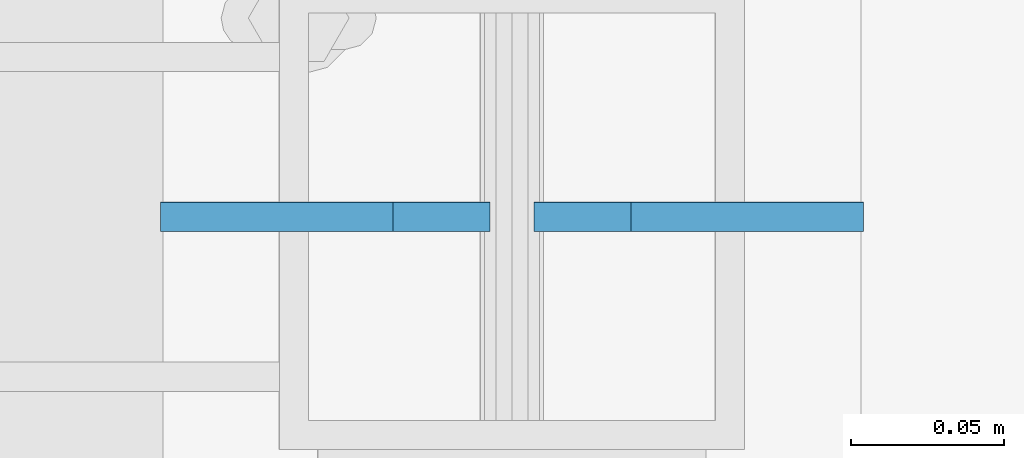
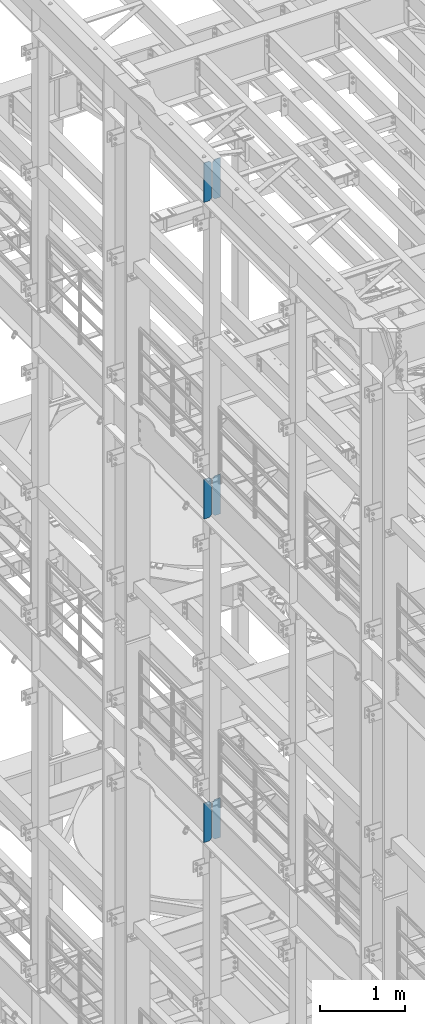
# One storey, part 1623 of 1876: 6 plates, 3 elements without a shape of their own.
"""IFC2X3 building model written with IfcOpenShell, lengths in millimetres."""

from ifc_helpers import new_model, si_unit, frame, origin_with_axes, place, context, subcontext, project, spatial, faceted_brep, material, type_object, element, aggregate, save


model = new_model("IFC2X3")

# Units and contexts
model_context = context("Model", 3, precision=1e-05, world=origin_with_axes())
body_context = subcontext(model_context, "Body", "Model", "MODEL_VIEW")
ifc_project = project(units=[si_unit("LENGTHUNIT", "METRE", prefix="MILLI"), si_unit("AREAUNIT", "SQUARE_METRE"), si_unit("VOLUMEUNIT", "CUBIC_METRE"), si_unit("MASSUNIT", "GRAM", prefix="KILO"), si_unit("TIMEUNIT", "SECOND"), si_unit("PLANEANGLEUNIT", "RADIAN"), si_unit("SOLIDANGLEUNIT", "STERADIAN"), si_unit("THERMODYNAMICTEMPERATUREUNIT", "DEGREE_CELSIUS"), si_unit("LUMINOUSINTENSITYUNIT", "LUMEN")], contexts=[model_context])

# Site, building, storey
site_placement = place(None, origin_with_axes())
site = spatial("IfcSite", under=ifc_project, at=site_placement, CompositionType="ELEMENT")
building_placement = place(site_placement, origin_with_axes())
building = spatial("IfcBuilding", under=site, at=building_placement, Name="Undefined", CompositionType="ELEMENT")
storey_placement = place(building_placement, origin_with_axes())
storey = spatial("IfcBuildingStorey", under=building, at=storey_placement, Name="Undefined", CompositionType="ELEMENT", Elevation=0.0)

# Assembly, plates
assembly_1_placement = place(storey_placement, origin_with_axes())
assembly_1 = element("IfcElementAssembly", 1, at=assembly_1_placement, inside=storey, Name="BEAM", AssemblyPlace="NOTDEFINED", PredefinedType="RIGID_FRAME")
ifc_material = material(Name="STEEL/A36")
plate_type = type_object("IfcPlateType", PredefinedType="NOTDEFINED")
plate_1_placement = place(assembly_1_placement, frame((115.093750392656, 5588.00666373244, 21958.3), z_axis=(0.0, 0.0, 1.0), x_axis=(-1.0, 0.0, 0.0)))
plate_1 = element("IfcPlate", 2, at=plate_1_placement, type_object=plate_type, material=ifc_material, Name="PLATE", context=body_context, shape_type="Brep", body=[
    faceted_brep([(0.0, -4.76249999999982, 0.0), (0.0, -4.76249999999982, 571.5), (0.0, 4.76249999999982, 571.5), (0.0, 4.76249999999982, 0.0), (76.1999969482422, -4.76249999999982, 571.5), (76.1999969482422, 4.76249999999982, 571.5), (107.949996948242, -4.76249999999982, 539.75), (107.949996948242, 4.76249999999982, 539.75), (107.949996948242, -4.76249999999982, 31.75), (107.949996948242, 4.76249999999982, 31.75), (76.1999969482422, -4.76250000000073, 0.0), (76.1999969482422, 4.76250000000073, 0.0)], [[[0, 1, 2, 3]], [[1, 4, 5, 2]], [[4, 6, 7, 5]], [[6, 8, 9, 7]], [[8, 10, 11, 9]], [[10, 0, 3, 11]], [[5, 7, 9, 11, 3, 2]], [[10, 8, 6, 4, 1, 0]]]),
])
plate_2_placement = place(assembly_1_placement, frame((-7.14374960734369, 5588.00666373244, 21958.3), z_axis=(0.0, 0.0, 1.0), x_axis=(-1.0, 0.0, 0.0)))
plate_2 = element("IfcPlate", 3, at=plate_2_placement, type_object=plate_type, material=ifc_material, Name="PLATE", context=body_context, shape_type="Brep", body=[
    faceted_brep([(-9.76996261670138e-14, -4.76250000000073, 31.75), (0.0, -4.76249999999982, 539.75), (0.0, 4.76249999999982, 539.75), (-9.76996261670138e-14, 4.76250000000073, 31.75), (31.75, -4.76249999999982, 571.5), (31.75, 4.76249999999982, 571.5), (107.949996948242, -4.76249999999982, 571.5), (107.949996948242, 4.76249999999982, 571.5), (107.950006484985, -4.76250000000073, 0.0), (107.950006484985, 4.76250000000073, 0.0), (31.75, -4.76250000000073, 0.0), (31.75, 4.76250000000073, 0.0)], [[[0, 1, 2, 3]], [[1, 4, 5, 2]], [[4, 6, 7, 5]], [[6, 8, 9, 7]], [[8, 10, 11, 9]], [[10, 0, 3, 11]], [[5, 7, 9, 11, 3, 2]], [[10, 8, 6, 4, 1, 0]]]),
])
aggregate(assembly_1, [plate_1, plate_2])

assembly_2_placement = place(storey_placement, origin_with_axes())
assembly_2 = element("IfcElementAssembly", 4, at=assembly_2_placement, inside=storey, Name="BEAM", AssemblyPlace="NOTDEFINED", PredefinedType="RIGID_FRAME")
plate_3_placement = place(assembly_2_placement, frame((115.093750395763, 5587.9999999841, 17386.3), z_axis=(0.0, 0.0, 1.0), x_axis=(-1.0, 0.0, 0.0)))
plate_3 = element("IfcPlate", 5, at=plate_3_placement, type_object=plate_type, material=ifc_material, Name="PLATE", context=body_context, shape_type="Brep", body=[
    faceted_brep([(0.0, -4.76249999999982, 0.0), (0.0, -4.76249999999982, 571.5), (0.0, 4.76249999999982, 571.5), (0.0, 4.76249999999982, 0.0), (76.1999969482422, -4.76249999999982, 571.5), (76.1999969482422, 4.76249999999982, 571.5), (107.949996948242, -4.76249999999982, 539.75), (107.949996948242, 4.76249999999982, 539.75), (107.949996948242, -4.76249999999982, 31.75), (107.949996948242, 4.76249999999982, 31.75), (76.1999969482422, -4.76250000000073, 0.0), (76.1999969482422, 4.76250000000073, 0.0)], [[[0, 1, 2, 3]], [[1, 4, 5, 2]], [[4, 6, 7, 5]], [[6, 8, 9, 7]], [[8, 10, 11, 9]], [[10, 0, 3, 11]], [[5, 7, 9, 11, 3, 2]], [[10, 8, 6, 4, 1, 0]]]),
])
plate_4_placement = place(assembly_2_placement, frame((-7.14374960423695, 5587.9999999841, 17386.3), z_axis=(0.0, 0.0, 1.0), x_axis=(-1.0, 0.0, 0.0)))
plate_4 = element("IfcPlate", 6, at=plate_4_placement, type_object=plate_type, material=ifc_material, Name="PLATE", context=body_context, shape_type="Brep", body=[
    faceted_brep([(-9.76996261670138e-14, -4.76250000000073, 31.75), (0.0, -4.76249999999982, 539.75), (0.0, 4.76249999999982, 539.75), (-9.76996261670138e-14, 4.76250000000073, 31.75), (31.75, -4.76249999999982, 571.5), (31.75, 4.76249999999982, 571.5), (107.949996948242, -4.76249999999982, 571.5), (107.949996948242, 4.76249999999982, 571.5), (107.950006484985, -4.76250000000073, 0.0), (107.950006484985, 4.76250000000073, 0.0), (31.75, -4.76250000000073, 0.0), (31.75, 4.76250000000073, 0.0)], [[[0, 1, 2, 3]], [[1, 4, 5, 2]], [[4, 6, 7, 5]], [[6, 8, 9, 7]], [[8, 10, 11, 9]], [[10, 0, 3, 11]], [[5, 7, 9, 11, 3, 2]], [[10, 8, 6, 4, 1, 0]]]),
])
aggregate(assembly_2, [plate_3, plate_4])

assembly_3_placement = place(storey_placement, origin_with_axes())
assembly_3 = element("IfcElementAssembly", 7, at=assembly_3_placement, inside=storey, Name="BEAM", AssemblyPlace="NOTDEFINED", PredefinedType="RIGID_FRAME")
plate_5_placement = place(assembly_3_placement, frame((115.093750395763, 5588.00000025618, 12712.7), z_axis=(0.0, 0.0, 1.0), x_axis=(-1.0, 0.0, 0.0)))
plate_5 = element("IfcPlate", 8, at=plate_5_placement, type_object=plate_type, material=ifc_material, Name="PLATE", context=body_context, shape_type="Brep", body=[
    faceted_brep([(0.0, -4.76249999999982, 0.0), (0.0, -4.76249999999982, 571.5), (0.0, 4.76249999999982, 571.5), (0.0, 4.76249999999982, 0.0), (76.1999969482422, -4.76249999999982, 571.5), (76.1999969482422, 4.76249999999982, 571.5), (107.949996948242, -4.76249999999982, 539.75), (107.949996948242, 4.76249999999982, 539.75), (107.949996948242, -4.76249999999982, 31.75), (107.949996948242, 4.76249999999982, 31.75), (76.1999969482422, -4.76250000000073, 0.0), (76.1999969482422, 4.76250000000073, 0.0)], [[[0, 1, 2, 3]], [[1, 4, 5, 2]], [[4, 6, 7, 5]], [[6, 8, 9, 7]], [[8, 10, 11, 9]], [[10, 0, 3, 11]], [[5, 7, 9, 11, 3, 2]], [[10, 8, 6, 4, 1, 0]]]),
])
plate_6_placement = place(assembly_3_placement, frame((-7.14374960423695, 5587.9999999841, 12712.7), z_axis=(0.0, 0.0, 1.0), x_axis=(-1.0, 0.0, 0.0)))
plate_6 = element("IfcPlate", 9, at=plate_6_placement, type_object=plate_type, material=ifc_material, Name="PLATE", context=body_context, shape_type="Brep", body=[
    faceted_brep([(-9.76996261670138e-14, -4.76250000000073, 31.75), (0.0, -4.76249999999982, 539.75), (0.0, 4.76249999999982, 539.75), (-9.76996261670138e-14, 4.76250000000073, 31.75), (31.75, -4.76249999999982, 571.5), (31.75, 4.76249999999982, 571.5), (107.949996948242, -4.76249999999982, 571.5), (107.949996948242, 4.76249999999982, 571.5), (107.950006484985, -4.76250000000073, 0.0), (107.950006484985, 4.76250000000073, 0.0), (31.75, -4.76250000000073, 0.0), (31.75, 4.76250000000073, 0.0)], [[[0, 1, 2, 3]], [[1, 4, 5, 2]], [[4, 6, 7, 5]], [[6, 8, 9, 7]], [[8, 10, 11, 9]], [[10, 0, 3, 11]], [[5, 7, 9, 11, 3, 2]], [[10, 8, 6, 4, 1, 0]]]),
])
aggregate(assembly_3, [plate_5, plate_6])

save(model, "model.ifc")
